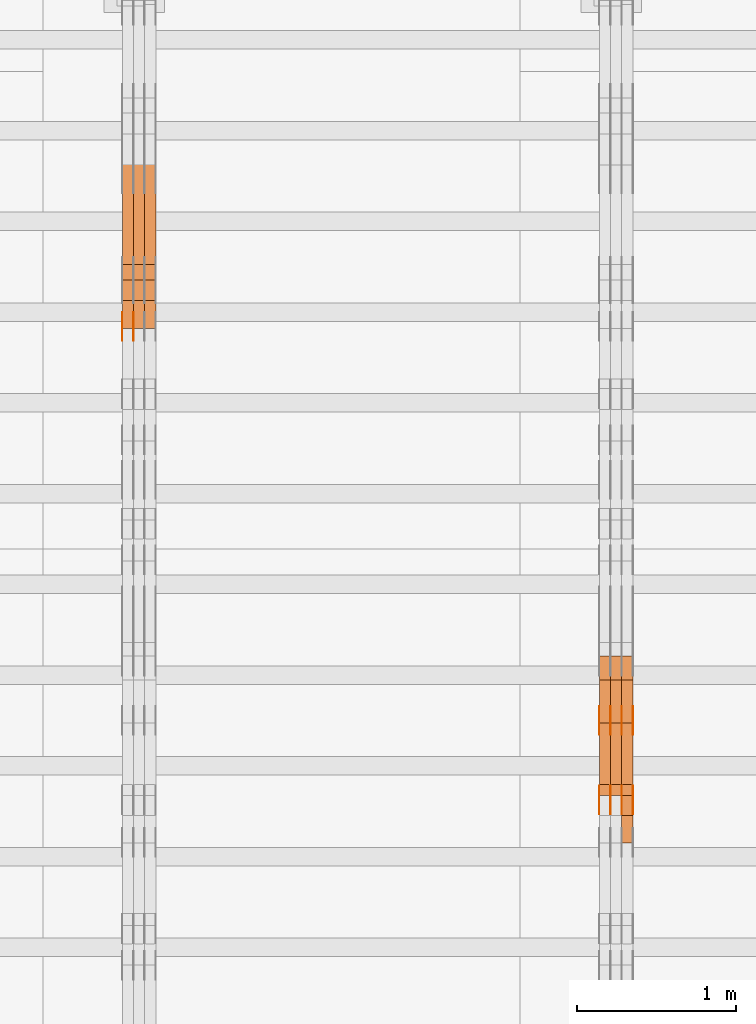
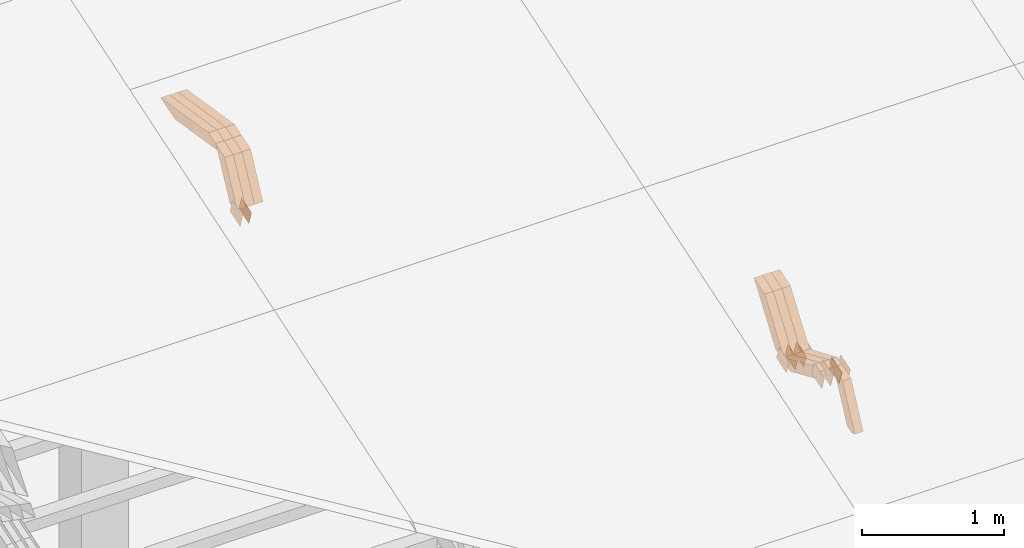
# One storey, part 256 of 385: 28 proxies.
"""IFC2X3 building model written with IfcOpenShell, lengths in millimetres."""

from ifc_helpers import new_model, entity, si_unit, converted_unit, derived_unit, direction, frame, origin, place, context, subcontext, project, spatial, polyline, outline, extrude, source, transform, mapped, material, type_object, type_shapes, element, save


model = new_model("IFC2X3")

# Units and contexts
model_context = context("Model", 3, precision=0.01, world=origin(), true_north=direction((6.12303176911189e-17, 1.0)))
body_context = subcontext(model_context, "Body", "Model", "MODEL_VIEW")
ifc_project = project(units=[si_unit("LENGTHUNIT", "METRE", prefix="MILLI"), si_unit("AREAUNIT", "SQUARE_METRE"), si_unit("VOLUMEUNIT", "CUBIC_METRE"), converted_unit("PLANEANGLEUNIT", "DEGREE", entity("IfcRatioMeasure", 0.0174532925199433), si_unit("PLANEANGLEUNIT", "RADIAN"), dimensions=[0, 0, 0, 0, 0, 0, 0]), si_unit("MASSUNIT", "GRAM", prefix="KILO"), derived_unit("MASSDENSITYUNIT", [(si_unit("MASSUNIT", "GRAM", prefix="KILO"), 1), (si_unit("LENGTHUNIT", "METRE"), -3)]), si_unit("TIMEUNIT", "SECOND"), si_unit("FREQUENCYUNIT", "HERTZ"), si_unit("THERMODYNAMICTEMPERATUREUNIT", "DEGREE_CELSIUS"), derived_unit("THERMALTRANSMITTANCEUNIT", [(si_unit("MASSUNIT", "GRAM", prefix="KILO"), 1), (si_unit("THERMODYNAMICTEMPERATUREUNIT", "KELVIN"), -1), (si_unit("TIMEUNIT", "SECOND"), -3)]), derived_unit("VOLUMETRICFLOWRATEUNIT", [(si_unit("LENGTHUNIT", "METRE"), 3), (si_unit("TIMEUNIT", "SECOND"), -1)]), si_unit("ELECTRICCURRENTUNIT", "AMPERE"), si_unit("ELECTRICVOLTAGEUNIT", "VOLT"), si_unit("POWERUNIT", "WATT"), si_unit("FORCEUNIT", "NEWTON", prefix="KILO"), si_unit("ILLUMINANCEUNIT", "LUX"), si_unit("LUMINOUSFLUXUNIT", "LUMEN"), si_unit("LUMINOUSINTENSITYUNIT", "CANDELA"), derived_unit("USERDEFINED", [(si_unit("MASSUNIT", "GRAM", prefix="KILO"), -1), (si_unit("LENGTHUNIT", "METRE"), -2), (si_unit("TIMEUNIT", "SECOND"), 3), (si_unit("LUMINOUSFLUXUNIT", "LUMEN"), 1)]), derived_unit("LINEARVELOCITYUNIT", [(si_unit("LENGTHUNIT", "METRE"), 1), (si_unit("TIMEUNIT", "SECOND"), -1)]), si_unit("PRESSUREUNIT", "PASCAL"), derived_unit("USERDEFINED", [(si_unit("LENGTHUNIT", "METRE"), -2), (si_unit("MASSUNIT", "GRAM", prefix="KILO"), 1), (si_unit("TIMEUNIT", "SECOND"), -2)])], contexts=[model_context])

# Site, building, storey
site_placement = place(None, origin())
site = spatial("IfcSite", under=ifc_project, at=site_placement, CompositionType="ELEMENT")
building_placement = place(site_placement, origin())
building = spatial("IfcBuilding", under=site, at=building_placement, CompositionType="ELEMENT")
storey_placement = place(building_placement, origin())
storey = spatial("IfcBuildingStorey", under=building, at=storey_placement, Name="Default", CompositionType="ELEMENT", Elevation=0.0)

# Proxies
ifc_material_1 = material(Name="IfcSurfaceStyle #448796")
building_element_proxy_type_1 = type_object("IfcBuildingElementProxyType", PredefinedType="NOTDEFINED", material=ifc_material_1)
shared_shape_1 = source(origin(), body_context, "Body", "SweptSolid", [
    extrude(outline(polyline([(-74.9998565677169, -60.0000596852269), (74.9998794200137, -60.0000596852269), (74.9998565677151, 60.0000596852269), (-74.9998794200119, 60.0000596852269), (-74.9998565677169, -60.0000596852269)])), frame((74.9998794200137, 60.0000596852269, 0.0), z_axis=(0.0, 0.0, 1.0), x_axis=(-1.0, 0.0, 0.0)), (0.0, 0.0, 1.0), 1.3),
])
type_shapes(building_element_proxy_type_1, [shared_shape_1])
proxy_1_placement = place(building_placement, frame((36386.3, 7527.6269081625, 1621.97418552253), z_axis=(-1.0, 0.0, 0.0), x_axis=(0.0, 0.951056516295124, 0.309016994375039)))
element("IfcBuildingElementProxy", 1, at=proxy_1_placement, inside=storey, type_object=building_element_proxy_type_1, material=ifc_material_1, context=body_context, shape_type="MappedRepresentation", body=[
    mapped(shared_shape_1, transform((0.0, 0.0, 0.0), scale=1.0)),
])
ifc_material_2 = material(Name="IfcSurfaceStyle #448739")
building_element_proxy_type_2 = type_object("IfcBuildingElementProxyType", PredefinedType="NOTDEFINED", material=ifc_material_2)
shared_shape_2 = source(origin(), body_context, "Body", "SweptSolid", [
    extrude(outline(polyline([(-74.9998565677169, -60.0000596852269), (74.9998794200137, -60.0000596852269), (74.9998565677151, 60.0000596852269), (-74.9998794200119, 60.0000596852269), (-74.9998565677169, -60.0000596852269)])), frame((74.9998794200137, 60.0000596852269, 0.0), z_axis=(0.0, 0.0, 1.0), x_axis=(-1.0, 0.0, 0.0)), (0.0, 0.0, 1.0), 1.3),
])
type_shapes(building_element_proxy_type_2, [shared_shape_2])
proxy_2_placement = place(building_placement, frame((36315.0, 7527.6269081625, 1621.97418552253), z_axis=(-1.0, 0.0, 0.0), x_axis=(0.0, 0.951056516295124, 0.309016994375039)))
element("IfcBuildingElementProxy", 2, at=proxy_2_placement, inside=storey, type_object=building_element_proxy_type_2, material=ifc_material_2, context=body_context, shape_type="MappedRepresentation", body=[
    mapped(shared_shape_2, transform((0.0, 0.0, 0.0), scale=1.0)),
])
ifc_material_3 = material(Name="IfcSurfaceStyle #448682")
building_element_proxy_type_3 = type_object("IfcBuildingElementProxyType", PredefinedType="NOTDEFINED", material=ifc_material_3)
shared_shape_3 = source(origin(), body_context, "Body", "SweptSolid", [
    extrude(outline(polyline([(-74.9998565677169, -60.0000596852269), (74.9998794200137, -60.0000596852269), (74.9998565677151, 60.0000596852269), (-74.9998794200119, 60.0000596852269), (-74.9998565677169, -60.0000596852269)])), frame((74.9998794200137, 60.0000596852269, 0.0), z_axis=(0.0, 0.0, 1.0), x_axis=(-1.0, 0.0, 0.0)), (0.0, 0.0, 1.0), 1.3),
])
type_shapes(building_element_proxy_type_3, [shared_shape_3])
proxy_3_placement = place(building_placement, frame((36316.3, 7527.6269081625, 1621.97418552253), z_axis=(-1.0, 0.0, 0.0), x_axis=(0.0, 0.951056516295124, 0.309016994375039)))
element("IfcBuildingElementProxy", 3, at=proxy_3_placement, inside=storey, type_object=building_element_proxy_type_3, material=ifc_material_3, context=body_context, shape_type="MappedRepresentation", body=[
    mapped(shared_shape_3, transform((0.0, 0.0, 0.0), scale=1.0)),
])
ifc_material_4 = material(Name="IfcSurfaceStyle #448625")
building_element_proxy_type_4 = type_object("IfcBuildingElementProxyType", PredefinedType="NOTDEFINED", material=ifc_material_4)
shared_shape_4 = source(origin(), body_context, "Body", "SweptSolid", [
    extrude(outline(polyline([(-74.9998565677169, -60.0000596852269), (74.9998794200137, -60.0000596852269), (74.9998565677151, 60.0000596852269), (-74.9998794200119, 60.0000596852269), (-74.9998565677169, -60.0000596852269)])), frame((74.9998794200137, 60.0000596852269, 0.0), z_axis=(0.0, 0.0, 1.0), x_axis=(-1.0, 0.0, 0.0)), (0.0, 0.0, 1.0), 1.29999999999999),
])
type_shapes(building_element_proxy_type_4, [shared_shape_4])
proxy_4_placement = place(building_placement, frame((36245.0, 7527.6269081625, 1621.97418552253), z_axis=(-1.0, 0.0, 0.0), x_axis=(0.0, 0.951056516295124, 0.309016994375039)))
element("IfcBuildingElementProxy", 4, at=proxy_4_placement, inside=storey, type_object=building_element_proxy_type_4, material=ifc_material_4, context=body_context, shape_type="MappedRepresentation", body=[
    mapped(shared_shape_4, transform((0.0, 0.0, 0.0), scale=1.0)),
])
ifc_material_5 = material(Name="IfcSurfaceStyle #448568")
building_element_proxy_type_5 = type_object("IfcBuildingElementProxyType", PredefinedType="NOTDEFINED", material=ifc_material_5)
shared_shape_5 = source(origin(), body_context, "Body", "SweptSolid", [
    extrude(outline(polyline([(-74.9998565677169, -60.0000596852269), (74.9998794200137, -60.0000596852269), (74.9998565677151, 60.0000596852269), (-74.9998794200119, 60.0000596852269), (-74.9998565677169, -60.0000596852269)])), frame((74.9998794200137, 60.0000596852269, 0.0), z_axis=(0.0, 0.0, 1.0), x_axis=(-1.0, 0.0, 0.0)), (0.0, 0.0, 1.0), 1.29999999999999),
])
type_shapes(building_element_proxy_type_5, [shared_shape_5])
proxy_5_placement = place(building_placement, frame((36246.3, 7527.6269081625, 1621.97418552253), z_axis=(-1.0, 0.0, 0.0), x_axis=(0.0, 0.951056516295124, 0.309016994375039)))
element("IfcBuildingElementProxy", 5, at=proxy_5_placement, inside=storey, type_object=building_element_proxy_type_5, material=ifc_material_5, context=body_context, shape_type="MappedRepresentation", body=[
    mapped(shared_shape_5, transform((0.0, 0.0, 0.0), scale=1.0)),
])
ifc_material_6 = material(Name="IfcSurfaceStyle #448511")
building_element_proxy_type_6 = type_object("IfcBuildingElementProxyType", PredefinedType="NOTDEFINED", material=ifc_material_6)
shared_shape_6 = source(origin(), body_context, "Body", "SweptSolid", [
    extrude(outline(polyline([(-74.9998565677169, -60.0000596852269), (74.9998794200137, -60.0000596852269), (74.9998565677151, 60.0000596852269), (-74.9998794200119, 60.0000596852269), (-74.9998565677169, -60.0000596852269)])), frame((74.9998794200137, 60.0000596852269, 0.0), z_axis=(0.0, 0.0, 1.0), x_axis=(-1.0, 0.0, 0.0)), (0.0, 0.0, 1.0), 1.29999999999999),
])
type_shapes(building_element_proxy_type_6, [shared_shape_6])
proxy_6_placement = place(building_placement, frame((36175.0, 7527.6269081625, 1621.97418552253), z_axis=(-1.0, 0.0, 0.0), x_axis=(0.0, 0.951056516295124, 0.309016994375039)))
element("IfcBuildingElementProxy", 6, at=proxy_6_placement, inside=storey, type_object=building_element_proxy_type_6, material=ifc_material_6, context=body_context, shape_type="MappedRepresentation", body=[
    mapped(shared_shape_6, transform((0.0, 0.0, 0.0), scale=1.0)),
])
ifc_material_7 = material(Name="IfcSurfaceStyle #438536")
building_element_proxy_type_7 = type_object("IfcBuildingElementProxyType", PredefinedType="NOTDEFINED", material=ifc_material_7)
shared_shape_7 = source(origin(), body_context, "Body", "SweptSolid", [
    extrude(outline(polyline([(-74.9998565677233, -60.0000596852342), (74.9998794200074, -60.0000596852342), (74.9998565677233, 60.0000596852342), (-74.9998794200074, 60.0000596852342), (-74.9998565677233, -60.0000596852342)])), frame((74.9998794200073, 60.0000596852342, 0.0), z_axis=(0.0, 0.0, 1.0), x_axis=(-1.0, 0.0, 0.0)), (0.0, 0.0, 1.0), 1.3),
])
type_shapes(building_element_proxy_type_7, [shared_shape_7])
proxy_7_placement = place(building_placement, frame((36386.3, 7029.15620503751, 1786.70025974129), z_axis=(-1.0, 0.0, 0.0), x_axis=(0.0, 0.951056516295154, 0.309016994374948)))
element("IfcBuildingElementProxy", 7, at=proxy_7_placement, inside=storey, type_object=building_element_proxy_type_7, material=ifc_material_7, context=body_context, shape_type="MappedRepresentation", body=[
    mapped(shared_shape_7, transform((0.0, 0.0, 0.0), scale=1.0)),
])
ifc_material_8 = material(Name="IfcSurfaceStyle #438479")
building_element_proxy_type_8 = type_object("IfcBuildingElementProxyType", PredefinedType="NOTDEFINED", material=ifc_material_8)
shared_shape_8 = source(origin(), body_context, "Body", "SweptSolid", [
    extrude(outline(polyline([(-74.9998565677233, -60.0000596852342), (74.9998794200074, -60.0000596852342), (74.9998565677233, 60.0000596852342), (-74.9998794200074, 60.0000596852342), (-74.9998565677233, -60.0000596852342)])), frame((74.9998794200073, 60.0000596852342, 0.0), z_axis=(0.0, 0.0, 1.0), x_axis=(-1.0, 0.0, 0.0)), (0.0, 0.0, 1.0), 1.3),
])
type_shapes(building_element_proxy_type_8, [shared_shape_8])
proxy_8_placement = place(building_placement, frame((36315.0, 7029.15620503751, 1786.70025974129), z_axis=(-1.0, 0.0, 0.0), x_axis=(0.0, 0.951056516295154, 0.309016994374948)))
element("IfcBuildingElementProxy", 8, at=proxy_8_placement, inside=storey, type_object=building_element_proxy_type_8, material=ifc_material_8, context=body_context, shape_type="MappedRepresentation", body=[
    mapped(shared_shape_8, transform((0.0, 0.0, 0.0), scale=1.0)),
])
ifc_material_9 = material(Name="IfcSurfaceStyle #438422")
building_element_proxy_type_9 = type_object("IfcBuildingElementProxyType", PredefinedType="NOTDEFINED", material=ifc_material_9)
shared_shape_9 = source(origin(), body_context, "Body", "SweptSolid", [
    extrude(outline(polyline([(-74.9998565677233, -60.0000596852342), (74.9998794200074, -60.0000596852342), (74.9998565677233, 60.0000596852342), (-74.9998794200074, 60.0000596852342), (-74.9998565677233, -60.0000596852342)])), frame((74.9998794200073, 60.0000596852342, 0.0), z_axis=(0.0, 0.0, 1.0), x_axis=(-1.0, 0.0, 0.0)), (0.0, 0.0, 1.0), 1.3),
])
type_shapes(building_element_proxy_type_9, [shared_shape_9])
proxy_9_placement = place(building_placement, frame((36316.3, 7029.15620503751, 1786.70025974129), z_axis=(-1.0, 0.0, 0.0), x_axis=(0.0, 0.951056516295154, 0.309016994374948)))
element("IfcBuildingElementProxy", 9, at=proxy_9_placement, inside=storey, type_object=building_element_proxy_type_9, material=ifc_material_9, context=body_context, shape_type="MappedRepresentation", body=[
    mapped(shared_shape_9, transform((0.0, 0.0, 0.0), scale=1.0)),
])
ifc_material_10 = material(Name="IfcSurfaceStyle #438365")
building_element_proxy_type_10 = type_object("IfcBuildingElementProxyType", PredefinedType="NOTDEFINED", material=ifc_material_10)
shared_shape_10 = source(origin(), body_context, "Body", "SweptSolid", [
    extrude(outline(polyline([(-74.9998565677233, -60.0000596852342), (74.9998794200074, -60.0000596852342), (74.9998565677233, 60.0000596852342), (-74.9998794200074, 60.0000596852342), (-74.9998565677233, -60.0000596852342)])), frame((74.9998794200073, 60.0000596852342, 0.0), z_axis=(0.0, 0.0, 1.0), x_axis=(-1.0, 0.0, 0.0)), (0.0, 0.0, 1.0), 1.29999999999999),
])
type_shapes(building_element_proxy_type_10, [shared_shape_10])
proxy_10_placement = place(building_placement, frame((36245.0, 7029.15620503751, 1786.70025974129), z_axis=(-1.0, 0.0, 0.0), x_axis=(0.0, 0.951056516295154, 0.309016994374948)))
element("IfcBuildingElementProxy", 10, at=proxy_10_placement, inside=storey, type_object=building_element_proxy_type_10, material=ifc_material_10, context=body_context, shape_type="MappedRepresentation", body=[
    mapped(shared_shape_10, transform((0.0, 0.0, 0.0), scale=1.0)),
])
ifc_material_11 = material(Name="IfcSurfaceStyle #438308")
building_element_proxy_type_11 = type_object("IfcBuildingElementProxyType", PredefinedType="NOTDEFINED", material=ifc_material_11)
shared_shape_11 = source(origin(), body_context, "Body", "SweptSolid", [
    extrude(outline(polyline([(-74.9998565677233, -60.0000596852342), (74.9998794200074, -60.0000596852342), (74.9998565677233, 60.0000596852342), (-74.9998794200074, 60.0000596852342), (-74.9998565677233, -60.0000596852342)])), frame((74.9998794200073, 60.0000596852342, 0.0), z_axis=(0.0, 0.0, 1.0), x_axis=(-1.0, 0.0, 0.0)), (0.0, 0.0, 1.0), 1.29999999999999),
])
type_shapes(building_element_proxy_type_11, [shared_shape_11])
proxy_11_placement = place(building_placement, frame((36246.3, 7029.15620503751, 1786.70025974129), z_axis=(-1.0, 0.0, 0.0), x_axis=(0.0, 0.951056516295154, 0.309016994374948)))
element("IfcBuildingElementProxy", 11, at=proxy_11_placement, inside=storey, type_object=building_element_proxy_type_11, material=ifc_material_11, context=body_context, shape_type="MappedRepresentation", body=[
    mapped(shared_shape_11, transform((0.0, 0.0, 0.0), scale=1.0)),
])
ifc_material_12 = material(Name="IfcSurfaceStyle #438251")
building_element_proxy_type_12 = type_object("IfcBuildingElementProxyType", PredefinedType="NOTDEFINED", material=ifc_material_12)
shared_shape_12 = source(origin(), body_context, "Body", "SweptSolid", [
    extrude(outline(polyline([(-74.9998565677233, -60.0000596852342), (74.9998794200074, -60.0000596852342), (74.9998565677233, 60.0000596852342), (-74.9998794200074, 60.0000596852342), (-74.9998565677233, -60.0000596852342)])), frame((74.9998794200073, 60.0000596852342, 0.0), z_axis=(0.0, 0.0, 1.0), x_axis=(-1.0, 0.0, 0.0)), (0.0, 0.0, 1.0), 1.29999999999999),
])
type_shapes(building_element_proxy_type_12, [shared_shape_12])
proxy_12_placement = place(building_placement, frame((36175.0, 7029.15620503751, 1786.70025974129), z_axis=(-1.0, 0.0, 0.0), x_axis=(0.0, 0.951056516295154, 0.309016994374948)))
element("IfcBuildingElementProxy", 12, at=proxy_12_placement, inside=storey, type_object=building_element_proxy_type_12, material=ifc_material_12, context=body_context, shape_type="MappedRepresentation", body=[
    mapped(shared_shape_12, transform((0.0, 0.0, 0.0), scale=1.0)),
])
ifc_material_13 = material(Name="IfcSurfaceStyle #426044")
building_element_proxy_type_13 = type_object("IfcBuildingElementProxyType", Name="T1-W17 426042", PredefinedType="NOTDEFINED", material=ifc_material_13)
shared_shape_13 = source(origin(), body_context, "Body", "SweptSolid", [
    extrude(outline(polyline([(-364.271754334175, -47.5002955168173), (154.762247185537, -47.5002955168173), (218.32500198375, 4.1746158945366e-05), (228.330650189718, 47.5002746437378), (-237.14614502483, 47.5002746437378), (-364.271754334175, -47.5002955168173)])), frame((228.330650189718, 47.5002746437378, 0.0), z_axis=(0.0, 0.0, 1.0), x_axis=(-1.0, 0.0, 0.0)), (0.0, 0.0, 1.0), 70.0),
])
type_shapes(building_element_proxy_type_13, [shared_shape_13])
proxy_13_placement = place(building_placement, frame((36385.0, 7603.591796875, 1617.27880859375), z_axis=(-1.0, 0.0, 0.0), x_axis=(0.0, 0.576852646364743, 0.816848226038346)))
element("IfcBuildingElementProxy", 13, at=proxy_13_placement, inside=storey, type_object=building_element_proxy_type_13, material=ifc_material_13, Name="T1-W17", context=body_context, shape_type="MappedRepresentation", body=[
    mapped(shared_shape_13, transform((0.0, 0.0, 0.0), scale=1.0)),
])
ifc_material_14 = material(Name="IfcSurfaceStyle #425978")
building_element_proxy_type_14 = type_object("IfcBuildingElementProxyType", Name="T1-W17 425976", PredefinedType="NOTDEFINED", material=ifc_material_14)
shared_shape_14 = source(origin(), body_context, "Body", "SweptSolid", [
    extrude(outline(polyline([(-364.271754334175, -47.5002955168173), (154.762247185537, -47.5002955168173), (218.32500198375, 4.1746158945366e-05), (228.330650189718, 47.5002746437378), (-237.14614502483, 47.5002746437378), (-364.271754334175, -47.5002955168173)])), frame((228.330650189718, 47.5002746437378, 0.0), z_axis=(0.0, 0.0, 1.0), x_axis=(-1.0, 0.0, 0.0)), (0.0, 0.0, 1.0), 70.0),
])
type_shapes(building_element_proxy_type_14, [shared_shape_14])
proxy_14_placement = place(building_placement, frame((36315.0, 7603.591796875, 1617.27880859375), z_axis=(-1.0, 0.0, 0.0), x_axis=(0.0, 0.576852646364743, 0.816848226038346)))
element("IfcBuildingElementProxy", 14, at=proxy_14_placement, inside=storey, type_object=building_element_proxy_type_14, material=ifc_material_14, Name="T1-W17", context=body_context, shape_type="MappedRepresentation", body=[
    mapped(shared_shape_14, transform((0.0, 0.0, 0.0), scale=1.0)),
])
ifc_material_15 = material(Name="IfcSurfaceStyle #425912")
building_element_proxy_type_15 = type_object("IfcBuildingElementProxyType", Name="T1-W17 425910", PredefinedType="NOTDEFINED", material=ifc_material_15)
shared_shape_15 = source(origin(), body_context, "Body", "SweptSolid", [
    extrude(outline(polyline([(-364.271754334175, -47.5002955168173), (154.762247185537, -47.5002955168173), (218.32500198375, 4.1746158945366e-05), (228.330650189718, 47.5002746437378), (-237.14614502483, 47.5002746437378), (-364.271754334175, -47.5002955168173)])), frame((228.330650189718, 47.5002746437378, 0.0), z_axis=(0.0, 0.0, 1.0), x_axis=(-1.0, 0.0, 0.0)), (0.0, 0.0, 1.0), 70.0),
])
type_shapes(building_element_proxy_type_15, [shared_shape_15])
proxy_15_placement = place(building_placement, frame((36245.0, 7603.591796875, 1617.27880859375), z_axis=(-1.0, 0.0, 0.0), x_axis=(0.0, 0.576852646364743, 0.816848226038346)))
element("IfcBuildingElementProxy", 15, at=proxy_15_placement, inside=storey, type_object=building_element_proxy_type_15, material=ifc_material_15, Name="T1-W17", context=body_context, shape_type="MappedRepresentation", body=[
    mapped(shared_shape_15, transform((0.0, 0.0, 0.0), scale=1.0)),
])
ifc_material_16 = material(Name="IfcSurfaceStyle #425648")
building_element_proxy_type_16 = type_object("IfcBuildingElementProxyType", Name="T1-W28 425646", PredefinedType="NOTDEFINED", material=ifc_material_16)
shared_shape_16 = source(origin(), body_context, "Body", "SweptSolid", [
    extrude(outline(polyline([(-217.926999432742, -47.5002417204892), (200.85556309928, -47.5002417204892), (198.503183549447, 8.27993157516647e-05), (144.500539771884, 47.5002003208314), (-325.932286987868, 47.5002003208314), (-217.926999432742, -47.5002417204892)])), frame((200.855855188284, 47.5002003208314, 0.0), z_axis=(0.0, 0.0, 1.0), x_axis=(-1.0, 0.0, 0.0)), (0.0, 0.0, 1.0), 70.0),
])
type_shapes(building_element_proxy_type_16, [shared_shape_16])
proxy_16_placement = place(building_placement, frame((36385.0, 7164.46308589723, 1806.71154838415), z_axis=(-1.0, 0.0, 0.0), x_axis=(0.0, 0.918207947119617, -0.396098681954861)))
element("IfcBuildingElementProxy", 16, at=proxy_16_placement, inside=storey, type_object=building_element_proxy_type_16, material=ifc_material_16, Name="T1-W28", context=body_context, shape_type="MappedRepresentation", body=[
    mapped(shared_shape_16, transform((0.0, 0.0, 0.0), scale=1.0)),
])
ifc_material_17 = material(Name="IfcSurfaceStyle #425582")
building_element_proxy_type_17 = type_object("IfcBuildingElementProxyType", Name="T1-W28 425580", PredefinedType="NOTDEFINED", material=ifc_material_17)
shared_shape_17 = source(origin(), body_context, "Body", "SweptSolid", [
    extrude(outline(polyline([(-217.926999432742, -47.5002417204892), (200.85556309928, -47.5002417204892), (198.503183549447, 8.27993157516647e-05), (144.500539771884, 47.5002003208314), (-325.932286987868, 47.5002003208314), (-217.926999432742, -47.5002417204892)])), frame((200.855855188284, 47.5002003208314, 0.0), z_axis=(0.0, 0.0, 1.0), x_axis=(-1.0, 0.0, 0.0)), (0.0, 0.0, 1.0), 70.0),
])
type_shapes(building_element_proxy_type_17, [shared_shape_17])
proxy_17_placement = place(building_placement, frame((36315.0, 7164.46308589723, 1806.71154838415), z_axis=(-1.0, 0.0, 0.0), x_axis=(0.0, 0.918207947119617, -0.396098681954861)))
element("IfcBuildingElementProxy", 17, at=proxy_17_placement, inside=storey, type_object=building_element_proxy_type_17, material=ifc_material_17, Name="T1-W28", context=body_context, shape_type="MappedRepresentation", body=[
    mapped(shared_shape_17, transform((0.0, 0.0, 0.0), scale=1.0)),
])
ifc_material_18 = material(Name="IfcSurfaceStyle #425516")
building_element_proxy_type_18 = type_object("IfcBuildingElementProxyType", Name="T1-W28 425514", PredefinedType="NOTDEFINED", material=ifc_material_18)
shared_shape_18 = source(origin(), body_context, "Body", "SweptSolid", [
    extrude(outline(polyline([(-217.926999432742, -47.5002417204892), (200.85556309928, -47.5002417204892), (198.503183549447, 8.27993157516647e-05), (144.500539771884, 47.5002003208314), (-325.932286987868, 47.5002003208314), (-217.926999432742, -47.5002417204892)])), frame((200.855855188284, 47.5002003208314, 0.0), z_axis=(0.0, 0.0, 1.0), x_axis=(-1.0, 0.0, 0.0)), (0.0, 0.0, 1.0), 70.0),
])
type_shapes(building_element_proxy_type_18, [shared_shape_18])
proxy_18_placement = place(building_placement, frame((36245.0, 7164.46308589723, 1806.71154838415), z_axis=(-1.0, 0.0, 0.0), x_axis=(0.0, 0.918207947119617, -0.396098681954861)))
element("IfcBuildingElementProxy", 18, at=proxy_18_placement, inside=storey, type_object=building_element_proxy_type_18, material=ifc_material_18, Name="T1-W28", context=body_context, shape_type="MappedRepresentation", body=[
    mapped(shared_shape_18, transform((0.0, 0.0, 0.0), scale=1.0)),
])
ifc_material_19 = material(Name="IfcSurfaceStyle #425252")
building_element_proxy_type_19 = type_object("IfcBuildingElementProxyType", Name="T1-W38 425250", PredefinedType="NOTDEFINED", material=ifc_material_19)
shared_shape_19 = source(origin(), body_context, "Body", "SweptSolid", [
    extrude(outline(polyline([(-298.027186733919, -47.5000251939178), (135.138415004037, -47.5000251939178), (181.282052802132, 0.000918984287993996), (187.347601017465, 47.4995657017738), (-205.740882089715, 47.4995657017739), (-298.027186733919, -47.5000251939178)])), frame((187.347846776827, 47.5001085012031, 0.0), z_axis=(0.0, 0.0, 1.0), x_axis=(-1.0, 0.0, 0.0)), (0.0, 0.0, 1.0), 70.0),
])
type_shapes(building_element_proxy_type_19, [shared_shape_19])
proxy_19_placement = place(building_placement, frame((36385.0, 6848.47987320449, 1368.44362234215), z_axis=(-1.0, 0.0, 0.0), x_axis=(0.0, 0.441034274474743, 0.897490261082836)))
element("IfcBuildingElementProxy", 19, at=proxy_19_placement, inside=storey, type_object=building_element_proxy_type_19, material=ifc_material_19, Name="T1-W38", context=body_context, shape_type="MappedRepresentation", body=[
    mapped(shared_shape_19, transform((0.0, 0.0, 0.0), scale=1.0)),
])
ifc_material_20 = material(Name="IfcSurfaceStyle #414535")
building_element_proxy_type_20 = type_object("IfcBuildingElementProxyType", PredefinedType="NOTDEFINED", material=ifc_material_20)
shared_shape_20 = source(origin(), body_context, "Body", "SweptSolid", [
    extrude(outline(polyline([(-74.9998754286189, -60.0000016373433), (74.9998605591118, -60.0000016373433), (74.9998754286189, 60.0000016373433), (-74.9998605591118, 60.0000016373433), (-74.9998754286189, -60.0000016373433)])), frame((74.9999131819004, 60.0000016373433, 0.0), z_axis=(0.0, 0.0, 1.0), x_axis=(-1.0, 0.0, 0.0)), (0.0, 0.0, 1.0), 1.29999999999999),
])
type_shapes(building_element_proxy_type_20, [shared_shape_20])
proxy_20_placement = place(building_placement, frame((33245.0, 10004.8612689908, 2426.87628052724), z_axis=(-1.0, 0.0, 0.0), x_axis=(0.0, 0.951056516295124, 0.309016994375039)))
element("IfcBuildingElementProxy", 20, at=proxy_20_placement, inside=storey, type_object=building_element_proxy_type_20, material=ifc_material_20, context=body_context, shape_type="MappedRepresentation", body=[
    mapped(shared_shape_20, transform((0.0, 0.0, 0.0), scale=1.0)),
])
ifc_material_21 = material(Name="IfcSurfaceStyle #414478")
building_element_proxy_type_21 = type_object("IfcBuildingElementProxyType", PredefinedType="NOTDEFINED", material=ifc_material_21)
shared_shape_21 = source(origin(), body_context, "Body", "SweptSolid", [
    extrude(outline(polyline([(-74.9998754286189, -60.0000016373433), (74.9998605591118, -60.0000016373433), (74.9998754286189, 60.0000016373433), (-74.9998605591118, 60.0000016373433), (-74.9998754286189, -60.0000016373433)])), frame((74.9999131819004, 60.0000016373433, 0.0), z_axis=(0.0, 0.0, 1.0), x_axis=(-1.0, 0.0, 0.0)), (0.0, 0.0, 1.0), 1.29999999999999),
])
type_shapes(building_element_proxy_type_21, [shared_shape_21])
proxy_21_placement = place(building_placement, frame((33246.3, 10004.8612689908, 2426.87628052724), z_axis=(-1.0, 0.0, 0.0), x_axis=(0.0, 0.951056516295124, 0.309016994375039)))
element("IfcBuildingElementProxy", 21, at=proxy_21_placement, inside=storey, type_object=building_element_proxy_type_21, material=ifc_material_21, context=body_context, shape_type="MappedRepresentation", body=[
    mapped(shared_shape_21, transform((0.0, 0.0, 0.0), scale=1.0)),
])
ifc_material_22 = material(Name="IfcSurfaceStyle #414421")
building_element_proxy_type_22 = type_object("IfcBuildingElementProxyType", PredefinedType="NOTDEFINED", material=ifc_material_22)
shared_shape_22 = source(origin(), body_context, "Body", "SweptSolid", [
    extrude(outline(polyline([(-74.9998754286189, -60.0000016373433), (74.9998605591118, -60.0000016373433), (74.9998754286189, 60.0000016373433), (-74.9998605591118, 60.0000016373433), (-74.9998754286189, -60.0000016373433)])), frame((74.9999131819004, 60.0000016373433, 0.0), z_axis=(0.0, 0.0, 1.0), x_axis=(-1.0, 0.0, 0.0)), (0.0, 0.0, 1.0), 1.29999999999999),
])
type_shapes(building_element_proxy_type_22, [shared_shape_22])
proxy_22_placement = place(building_placement, frame((33175.0, 10004.8612689908, 2426.87628052724), z_axis=(-1.0, 0.0, 0.0), x_axis=(0.0, 0.951056516295124, 0.309016994375039)))
element("IfcBuildingElementProxy", 22, at=proxy_22_placement, inside=storey, type_object=building_element_proxy_type_22, material=ifc_material_22, context=body_context, shape_type="MappedRepresentation", body=[
    mapped(shared_shape_22, transform((0.0, 0.0, 0.0), scale=1.0)),
])
ifc_material_23 = material(Name="IfcSurfaceStyle #394384")
building_element_proxy_type_23 = type_object("IfcBuildingElementProxyType", Name="T1-W5 394382", PredefinedType="NOTDEFINED", material=ifc_material_23)
shared_shape_23 = source(origin(), body_context, "Body", "SweptSolid", [
    extrude(outline(polyline([(-301.214270081322, -47.5000783565111), (303.980395954293, -47.5000783565111), (288.664123931657, 0.000197935560590153), (195.704076557203, 47.4999793887309), (-487.134326361831, 47.4999793887309), (-301.214270081322, -47.5000783565111)])), frame((303.980395954293, 47.5001815410909, 0.0), z_axis=(0.0, 0.0, 1.0), x_axis=(-1.0, 0.0, 0.0)), (0.0, 0.0, 1.0), 70.0),
])
type_shapes(building_element_proxy_type_23, [shared_shape_23])
proxy_23_placement = place(building_placement, frame((33385.0, 10379.2051671398, 2863.91176079486), z_axis=(-1.0, 0.0, 0.0), x_axis=(0.0, 0.987508363398486, -0.1575665961365)))
element("IfcBuildingElementProxy", 23, at=proxy_23_placement, inside=storey, type_object=building_element_proxy_type_23, material=ifc_material_23, Name="T1-W5", context=body_context, shape_type="MappedRepresentation", body=[
    mapped(shared_shape_23, transform((0.0, 0.0, 0.0), scale=1.0)),
])
ifc_material_24 = material(Name="IfcSurfaceStyle #394318")
building_element_proxy_type_24 = type_object("IfcBuildingElementProxyType", Name="T1-W5 394316", PredefinedType="NOTDEFINED", material=ifc_material_24)
shared_shape_24 = source(origin(), body_context, "Body", "SweptSolid", [
    extrude(outline(polyline([(-301.214270081322, -47.5000783565111), (303.980395954293, -47.5000783565111), (288.664123931657, 0.000197935560590153), (195.704076557203, 47.4999793887309), (-487.134326361831, 47.4999793887309), (-301.214270081322, -47.5000783565111)])), frame((303.980395954293, 47.5001815410909, 0.0), z_axis=(0.0, 0.0, 1.0), x_axis=(-1.0, 0.0, 0.0)), (0.0, 0.0, 1.0), 70.0),
])
type_shapes(building_element_proxy_type_24, [shared_shape_24])
proxy_24_placement = place(building_placement, frame((33315.0, 10379.2051671398, 2863.91176079486), z_axis=(-1.0, 0.0, 0.0), x_axis=(0.0, 0.987508363398486, -0.1575665961365)))
element("IfcBuildingElementProxy", 24, at=proxy_24_placement, inside=storey, type_object=building_element_proxy_type_24, material=ifc_material_24, Name="T1-W5", context=body_context, shape_type="MappedRepresentation", body=[
    mapped(shared_shape_24, transform((0.0, 0.0, 0.0), scale=1.0)),
])
ifc_material_25 = material(Name="IfcSurfaceStyle #394252")
building_element_proxy_type_25 = type_object("IfcBuildingElementProxyType", Name="T1-W5 394250", PredefinedType="NOTDEFINED", material=ifc_material_25)
shared_shape_25 = source(origin(), body_context, "Body", "SweptSolid", [
    extrude(outline(polyline([(-301.214270081322, -47.5000783565111), (303.980395954293, -47.5000783565111), (288.664123931657, 0.000197935560590153), (195.704076557203, 47.4999793887309), (-487.134326361831, 47.4999793887309), (-301.214270081322, -47.5000783565111)])), frame((303.980395954293, 47.5001815410909, 0.0), z_axis=(0.0, 0.0, 1.0), x_axis=(-1.0, 0.0, 0.0)), (0.0, 0.0, 1.0), 70.0),
])
type_shapes(building_element_proxy_type_25, [shared_shape_25])
proxy_25_placement = place(building_placement, frame((33245.0, 10379.2051671398, 2863.91176079486), z_axis=(-1.0, 0.0, 0.0), x_axis=(0.0, 0.987508363398486, -0.1575665961365)))
element("IfcBuildingElementProxy", 25, at=proxy_25_placement, inside=storey, type_object=building_element_proxy_type_25, material=ifc_material_25, Name="T1-W5", context=body_context, shape_type="MappedRepresentation", body=[
    mapped(shared_shape_25, transform((0.0, 0.0, 0.0), scale=1.0)),
])
ifc_material_26 = material(Name="IfcSurfaceStyle #393988")
building_element_proxy_type_26 = type_object("IfcBuildingElementProxyType", Name="T1-W37 393986", PredefinedType="NOTDEFINED", material=ifc_material_26)
shared_shape_26 = source(origin(), body_context, "Body", "SweptSolid", [
    extrude(outline(polyline([(111.787482004227, -179.289397746839), (245.990585035629, -179.289397746839), (-64.0177573255029, 131.410401861866), (-131.116409377007, 131.410958895698), (-162.643900337347, 95.757434736113), (111.787482004227, -179.289397746839)])), frame((185.635323570343, 47.5011799885346, 0.0), z_axis=(0.0, 0.0, 1.0), x_axis=(0.706316677358935, 0.707896003156279, 0.0)), (0.0, 0.0, 1.0), 70.0),
])
type_shapes(building_element_proxy_type_26, [shared_shape_26])
proxy_26_placement = place(building_placement, frame((33385.0, 10081.8581176196, 2424.08390440728), z_axis=(-1.0, 0.0, 0.0), x_axis=(0.0, 0.452995827831714, 0.891512635898707)))
element("IfcBuildingElementProxy", 26, at=proxy_26_placement, inside=storey, type_object=building_element_proxy_type_26, material=ifc_material_26, Name="T1-W37", context=body_context, shape_type="MappedRepresentation", body=[
    mapped(shared_shape_26, transform((0.0, 0.0, 0.0), scale=1.0)),
])
ifc_material_27 = material(Name="IfcSurfaceStyle #393922")
building_element_proxy_type_27 = type_object("IfcBuildingElementProxyType", Name="T1-W37 393920", PredefinedType="NOTDEFINED", material=ifc_material_27)
shared_shape_27 = source(origin(), body_context, "Body", "SweptSolid", [
    extrude(outline(polyline([(111.787482004227, -179.289397746839), (245.990585035629, -179.289397746839), (-64.0177573255029, 131.410401861866), (-131.116409377007, 131.410958895698), (-162.643900337347, 95.757434736113), (111.787482004227, -179.289397746839)])), frame((185.635323570343, 47.5011799885346, 0.0), z_axis=(0.0, 0.0, 1.0), x_axis=(0.706316677358935, 0.707896003156279, 0.0)), (0.0, 0.0, 1.0), 70.0),
])
type_shapes(building_element_proxy_type_27, [shared_shape_27])
proxy_27_placement = place(building_placement, frame((33315.0, 10081.8581176196, 2424.08390440728), z_axis=(-1.0, 0.0, 0.0), x_axis=(0.0, 0.452995827831714, 0.891512635898707)))
element("IfcBuildingElementProxy", 27, at=proxy_27_placement, inside=storey, type_object=building_element_proxy_type_27, material=ifc_material_27, Name="T1-W37", context=body_context, shape_type="MappedRepresentation", body=[
    mapped(shared_shape_27, transform((0.0, 0.0, 0.0), scale=1.0)),
])
ifc_material_28 = material(Name="IfcSurfaceStyle #393856")
building_element_proxy_type_28 = type_object("IfcBuildingElementProxyType", Name="T1-W37 393854", PredefinedType="NOTDEFINED", material=ifc_material_28)
shared_shape_28 = source(origin(), body_context, "Body", "SweptSolid", [
    extrude(outline(polyline([(111.787482004227, -179.289397746839), (245.990585035629, -179.289397746839), (-64.0177573255029, 131.410401861866), (-131.116409377007, 131.410958895698), (-162.643900337347, 95.757434736113), (111.787482004227, -179.289397746839)])), frame((185.635323570343, 47.5011799885346, 0.0), z_axis=(0.0, 0.0, 1.0), x_axis=(0.706316677358935, 0.707896003156279, 0.0)), (0.0, 0.0, 1.0), 70.0),
])
type_shapes(building_element_proxy_type_28, [shared_shape_28])
proxy_28_placement = place(building_placement, frame((33245.0, 10081.8581176196, 2424.08390440728), z_axis=(-1.0, 0.0, 0.0), x_axis=(0.0, 0.452995827831714, 0.891512635898707)))
element("IfcBuildingElementProxy", 28, at=proxy_28_placement, inside=storey, type_object=building_element_proxy_type_28, material=ifc_material_28, Name="T1-W37", context=body_context, shape_type="MappedRepresentation", body=[
    mapped(shared_shape_28, transform((0.0, 0.0, 0.0), scale=1.0)),
])

save(model, "model.ifc")
